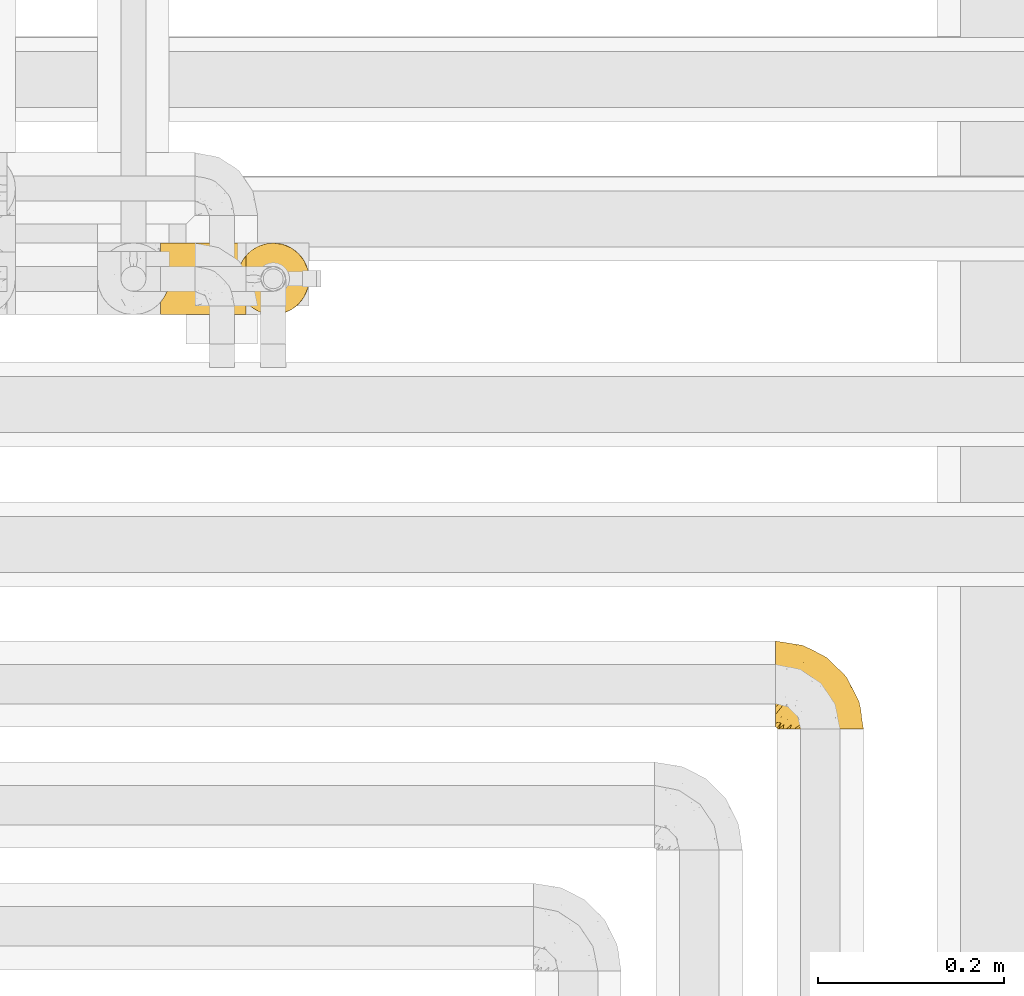
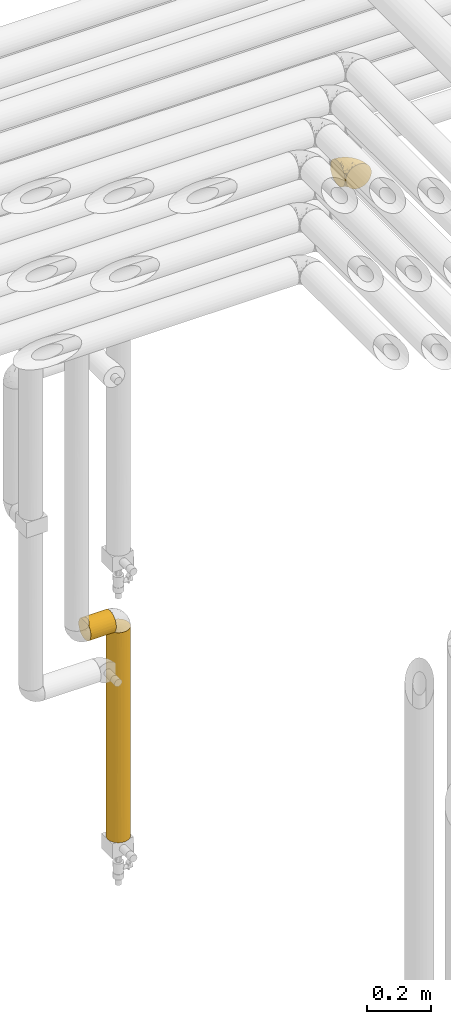
# One storey, part 278 of 827: 3 coverings.
"""IFC2X3 building model written with IfcOpenShell, lengths in millimetres."""

from ifc_helpers import new_model, entity, si_unit, converted_unit, derived_unit, direction, frame, origin, place, context, subcontext, project, spatial, faceted_brep, element, save


model = new_model("IFC2X3")

# Units and contexts
model_context = context("Model", 3, precision=0.01, world=origin(), true_north=direction((6.12303176911189e-17, 1.0)))
body_context = subcontext(model_context, "Body", "Model", "MODEL_VIEW")
ifc_project = project(units=[si_unit("LENGTHUNIT", "METRE", prefix="MILLI"), si_unit("AREAUNIT", "SQUARE_METRE"), si_unit("VOLUMEUNIT", "CUBIC_METRE"), converted_unit("PLANEANGLEUNIT", "DEGREE", entity("IfcRatioMeasure", 0.0174532925199433), si_unit("PLANEANGLEUNIT", "RADIAN"), dimensions=[0, 0, 0, 0, 0, 0, 0]), si_unit("MASSUNIT", "GRAM", prefix="KILO"), derived_unit("MASSDENSITYUNIT", [(si_unit("MASSUNIT", "GRAM", prefix="KILO"), 1), (si_unit("LENGTHUNIT", "METRE"), -3)]), derived_unit("MOMENTOFINERTIAUNIT", [(si_unit("LENGTHUNIT", "METRE"), 4)]), si_unit("TIMEUNIT", "SECOND"), si_unit("FREQUENCYUNIT", "HERTZ"), si_unit("THERMODYNAMICTEMPERATUREUNIT", "DEGREE_CELSIUS"), derived_unit("THERMALTRANSMITTANCEUNIT", [(si_unit("MASSUNIT", "GRAM", prefix="KILO"), 1), (si_unit("THERMODYNAMICTEMPERATUREUNIT", "KELVIN"), -1), (si_unit("TIMEUNIT", "SECOND"), -3)]), derived_unit("VOLUMETRICFLOWRATEUNIT", [(si_unit("LENGTHUNIT", "METRE"), 3), (si_unit("TIMEUNIT", "SECOND"), -1)]), derived_unit("MASSFLOWRATEUNIT", [(si_unit("MASSUNIT", "GRAM", prefix="KILO"), 1), (si_unit("TIMEUNIT", "SECOND"), -1)]), derived_unit("ROTATIONALFREQUENCYUNIT", [(si_unit("TIMEUNIT", "SECOND"), -1)]), si_unit("ELECTRICCURRENTUNIT", "AMPERE"), si_unit("ELECTRICVOLTAGEUNIT", "VOLT"), si_unit("POWERUNIT", "WATT"), si_unit("FORCEUNIT", "NEWTON", prefix="KILO"), si_unit("ILLUMINANCEUNIT", "LUX"), si_unit("LUMINOUSFLUXUNIT", "LUMEN"), si_unit("LUMINOUSINTENSITYUNIT", "CANDELA"), derived_unit("USERDEFINED", [(si_unit("MASSUNIT", "GRAM", prefix="KILO"), -1), (si_unit("LENGTHUNIT", "METRE"), -2), (si_unit("TIMEUNIT", "SECOND"), 3), (si_unit("LUMINOUSFLUXUNIT", "LUMEN"), 1)]), derived_unit("LINEARVELOCITYUNIT", [(si_unit("LENGTHUNIT", "METRE"), 1), (si_unit("TIMEUNIT", "SECOND"), -1)]), si_unit("PRESSUREUNIT", "PASCAL"), derived_unit("USERDEFINED", [(si_unit("LENGTHUNIT", "METRE"), -2), (si_unit("MASSUNIT", "GRAM", prefix="KILO"), 1), (si_unit("TIMEUNIT", "SECOND"), -2)]), derived_unit("LINEARFORCEUNIT", [(si_unit("MASSUNIT", "GRAM", prefix="KILO"), 1), (si_unit("LENGTHUNIT", "METRE"), 1), (si_unit("TIMEUNIT", "SECOND"), -2), (si_unit("LENGTHUNIT", "METRE"), -1)]), derived_unit("PLANARFORCEUNIT", [(si_unit("MASSUNIT", "GRAM", prefix="KILO"), 1), (si_unit("LENGTHUNIT", "METRE"), 1), (si_unit("TIMEUNIT", "SECOND"), -2), (si_unit("LENGTHUNIT", "METRE"), -2)])], contexts=[model_context])

# Site, building, storey
site_placement = place(None, origin())
site = spatial("IfcSite", under=ifc_project, at=site_placement, CompositionType="ELEMENT")
building_placement = place(site_placement, origin())
building = spatial("IfcBuilding", under=site, at=building_placement, CompositionType="ELEMENT")
storey_placement = place(building_placement, frame((0.0, 0.0, 28200.0)))
storey = spatial("IfcBuildingStorey", under=building, at=storey_placement, Name="08", CompositionType="ELEMENT", Elevation=28200.0)

# Coverings
covering_1_placement = place(storey_placement, frame((35680.44, 14440.41, 2952.2)))
element("IfcCovering", 1, at=covering_1_placement, inside=storey, Name=":ADSK_", ObjectType=":ADSK_", PredefinedType="INSULATION", context=body_context, shape_type="Brep", body=[
    faceted_brep([(1.6, 59.88, 92.84), (1.6, 69.65, 89.42), (1.6, 78.41, 83.91), (1.6, 85.72, 76.59), (1.6, 91.22, 67.83), (1.6, 94.64, 58.07), (1.6, 95.8, 47.8), (1.6, 94.64, 37.51), (1.6, 91.22, 27.74), (1.6, 85.71, 18.98), (1.6, 78.39, 11.67), (1.6, 69.63, 6.17), (1.6, 59.87, 2.75), (1.6, 49.6, 1.6), (1.6, 45.45, 2.06), (1.6, 42.38, 2.41), (1.6, 39.31, 2.75), (1.6, 34.43, 4.46), (1.6, 29.54, 6.17), (1.6, 25.16, 8.93), (1.6, 20.78, 11.68), (1.6, 17.13, 15.34), (1.6, 13.47, 19.0), (1.6, 7.97, 27.76), (1.6, 6.26, 32.64), (1.6, 4.55, 37.52), (1.6, 3.4, 47.8), (1.6, 4.55, 58.08), (1.6, 6.26, 62.96), (1.6, 7.97, 67.85), (1.6, 13.48, 76.61), (1.6, 17.14, 80.26), (1.6, 20.8, 83.92), (1.6, 25.18, 86.67), (1.6, 29.56, 89.42), (1.6, 34.44, 91.13), (1.6, 39.32, 92.84), (1.6, 42.39, 93.18), (1.6, 45.45, 93.53), (1.6, 49.6, 94.0), (3.4, 1.6, 47.8), (4.97, 1.6, 35.84), (9.58, 1.6, 24.7), (13.26, 1.6, 19.91), (16.93, 1.6, 15.13), (21.71, 1.6, 11.46), (26.5, 1.6, 7.78), (32.07, 1.6, 5.48), (37.64, 1.6, 3.17), (41.25, 1.6, 2.69), (43.34, 1.6, 2.42), (45.42, 1.6, 2.14), (49.6, 1.6, 1.6), (61.55, 1.6, 3.17), (72.7, 1.6, 7.78), (82.26, 1.6, 15.13), (89.61, 1.6, 24.7), (94.22, 1.6, 35.84), (95.8, 1.6, 47.8), (94.22, 1.6, 59.75), (89.61, 1.6, 70.9), (82.26, 1.6, 80.46), (72.7, 1.6, 87.81), (61.55, 1.6, 92.42), (49.6, 1.6, 94.0), (45.42, 1.6, 93.45), (41.25, 1.6, 92.9), (37.64, 1.6, 92.42), (32.07, 1.6, 90.11), (26.5, 1.6, 87.81), (21.71, 1.6, 84.13), (16.93, 1.6, 80.46), (13.26, 1.6, 75.68), (9.58, 1.6, 70.9), (4.97, 1.6, 59.75), (81.55, 36.81, 71.98), (90.4, 23.28, 63.6), (83.0, 45.8, 59.72), (91.18, 30.7, 47.8), (93.13, 21.2, 55.16), (94.0, 12.96, 47.8), (66.19, 66.19, 63.76), (70.92, 54.51, 72.22), (85.95, 17.98, 74.18), (49.74, 36.69, 92.52), (35.54, 35.54, 94.0), (38.14, 31.64, 94.0), (40.74, 27.75, 94.0), (43.34, 23.86, 94.0), (45.94, 19.96, 94.0), (77.59, 22.8, 82.14), (71.17, 42.67, 80.34), (65.81, 33.21, 87.52), (59.03, 59.45, 79.59), (45.85, 71.5, 78.25), (45.79, 62.66, 85.01), (41.42, 54.5, 90.25), (34.51, 47.57, 93.2), (56.04, 48.81, 87.23), (15.15, 74.98, 85.55), (56.51, 18.7, 93.0), (68.39, 15.75, 89.31), (23.33, 91.17, 61.31), (42.86, 85.28, 56.86), (39.42, 82.58, 68.34), (53.58, 75.78, 65.71), (59.17, 74.98, 56.99), (59.06, 67.27, 72.15), (22.63, 87.38, 70.34), (20.55, 82.04, 78.36), (12.96, 94.0, 47.8), (56.96, 77.8, 47.8), (67.38, 67.38, 47.8), (18.72, 56.2, 93.06), (5.33, 48.85, 94.0), (9.07, 48.11, 94.0), (11.79, 47.57, 94.0), (14.51, 47.03, 94.0), (17.24, 46.48, 94.0), (19.96, 45.94, 94.0), (21.03, 65.78, 89.88), (46.48, 17.24, 94.0), (47.03, 14.51, 94.0), (47.57, 11.79, 94.0), (48.11, 9.07, 94.0), (48.48, 7.2, 94.0), (48.85, 5.33, 94.0), (30.7, 91.18, 47.8), (23.86, 43.34, 94.0), (27.75, 40.74, 94.0), (31.64, 38.14, 94.0), (31.26, 72.73, 83.7), (77.8, 56.96, 47.8), (72.75, 62.23, 55.9), (43.83, 84.49, 47.8), (84.49, 43.83, 47.8), (14.58, 12.05, 81.75), (16.17, 18.95, 86.43), (10.82, 13.02, 79.8), (4.64, 8.34, 69.84), (7.71, 14.63, 79.5), (25.13, 11.09, 88.08), (32.66, 13.66, 91.6), (34.94, 20.08, 92.93), (36.76, 9.61, 92.43), (40.48, 9.48, 93.24), (39.25, 16.1, 93.36), (3.69, 3.42, 57.25), (13.99, 26.63, 89.41), (21.85, 33.72, 92.89), (17.93, 34.77, 92.66), (15.11, 6.75, 79.58), (21.14, 13.31, 86.51), (7.21, 19.94, 83.91), (9.47, 27.05, 88.76), (32.27, 8.67, 90.94), (25.68, 26.11, 91.94), (22.18, 29.3, 91.98), (18.79, 6.32, 82.79), (10.12, 39.92, 93.16), (10.45, 6.04, 73.94), (11.29, 34.4, 91.89), (2.87, 2.87, 47.8), (31.16, 20.92, 92.22), (12.7, 21.11, 86.29), (6.31, 27.43, 88.56), (25.62, 7.54, 87.72), (21.18, 18.45, 88.33), (28.81, 23.88, 92.18), (7.45, 7.77, 71.78), (21.17, 18.43, 7.27), (16.17, 18.93, 9.17), (25.69, 26.08, 3.66), (48.85, 5.33, 1.6), (47.03, 14.51, 1.6), (47.57, 11.79, 1.6), (48.11, 9.07, 1.6), (3.69, 3.42, 38.35), (7.44, 7.76, 23.84), (14.51, 47.03, 1.6), (11.79, 47.57, 1.6), (5.33, 48.85, 1.6), (9.07, 48.11, 1.6), (7.71, 14.62, 16.1), (9.47, 27.03, 6.84), (34.94, 20.08, 2.66), (31.16, 20.92, 3.37), (40.74, 27.75, 1.6), (38.14, 31.64, 1.6), (18.79, 6.33, 12.8), (36.76, 9.61, 3.16), (40.48, 9.48, 2.35), (4.63, 8.33, 25.77), (21.14, 13.3, 9.09), (15.11, 6.74, 16.02), (14.58, 12.04, 13.85), (43.34, 23.86, 1.6), (45.94, 19.96, 1.6), (39.25, 16.1, 2.23), (7.21, 19.93, 11.69), (12.69, 21.1, 9.31), (10.14, 39.92, 2.43), (21.81, 33.68, 2.71), (22.19, 29.28, 3.61), (14.0, 26.62, 6.18), (6.66, 27.87, 6.77), (17.92, 34.75, 2.93), (10.45, 6.04, 21.66), (31.64, 38.14, 1.6), (10.64, 12.79, 16.09), (11.31, 34.41, 3.7), (19.96, 45.94, 1.6), (23.86, 43.34, 1.6), (27.75, 40.74, 1.6), (32.66, 13.66, 3.99), (46.48, 17.24, 1.6), (32.27, 8.67, 4.65), (25.13, 11.09, 7.51), (35.54, 35.54, 1.6), (28.77, 23.83, 3.43), (23.36, 6.03, 9.46), (17.24, 46.48, 1.6), (47.58, 34.52, 2.4), (93.13, 21.2, 40.43), (77.44, 23.82, 13.57), (66.78, 41.32, 11.3), (71.68, 47.62, 18.65), (74.96, 52.66, 27.26), (81.55, 36.81, 23.61), (36.7, 49.75, 3.07), (56.9, 19.07, 2.69), (83.0, 45.8, 35.87), (90.4, 23.28, 31.99), (67.83, 21.35, 6.71), (85.95, 17.98, 21.41), (39.41, 82.57, 27.24), (23.33, 91.17, 34.26), (42.87, 85.27, 38.73), (53.92, 73.89, 26.97), (66.19, 66.19, 31.83), (64.12, 62.43, 23.4), (33.13, 63.53, 6.91), (23.1, 58.45, 3.4), (16.98, 67.16, 5.84), (55.72, 76.72, 35.73), (72.75, 62.22, 39.69), (23.77, 81.54, 17.6), (18.41, 74.8, 10.38), (43.7, 75.83, 20.6), (54.53, 41.45, 5.36), (17.73, 88.2, 24.84), (38.98, 71.6, 13.87), (50.28, 56.23, 9.06), (59.02, 59.44, 15.99)], [[[0, 1, 2, 3, 4, 5, 6, 7, 8, 9, 10, 11, 12, 13, 14, 15, 16, 17, 18, 19, 20, 21, 22, 23, 24, 25, 26, 27, 28, 29, 30, 31, 32, 33, 34, 35, 36, 37, 38, 39]], [[40, 41, 42, 43, 44, 45, 46, 47, 48, 49, 50, 51, 52, 53, 54, 55, 56, 57, 58, 59, 60, 61, 62, 63, 64, 65, 66, 67, 68, 69, 70, 71, 72, 73, 74]], [[75, 76, 77]], [[78, 79, 80]], [[77, 81, 82]], [[76, 75, 83]], [[84, 85, 86, 87, 88, 89]], [[90, 91, 92]], [[76, 60, 59]], [[93, 94, 95]], [[90, 62, 61]], [[83, 61, 60]], [[96, 97, 84]], [[98, 93, 95]], [[2, 1, 99]], [[100, 84, 89]], [[62, 101, 63]], [[4, 102, 5]], [[92, 84, 100]], [[103, 102, 104]], [[103, 105, 106]], [[93, 107, 94]], [[3, 108, 4]], [[92, 101, 90]], [[108, 3, 109]], [[102, 110, 5]], [[93, 82, 107]], [[102, 108, 104]], [[111, 106, 112]], [[109, 2, 99]], [[113, 39, 114, 115, 116, 117, 118, 119]], [[120, 0, 113]], [[100, 89, 121, 122, 123, 124, 125, 126, 64]], [[127, 102, 103]], [[97, 119, 128, 129, 130, 85]], [[99, 120, 131]], [[132, 133, 77]], [[59, 80, 79]], [[3, 2, 109]], [[98, 84, 92]], [[94, 109, 131]], [[120, 1, 0]], [[93, 91, 82]], [[104, 94, 105]], [[97, 113, 119]], [[95, 120, 96]], [[83, 90, 61]], [[91, 93, 98]], [[64, 63, 100]], [[100, 63, 101]], [[77, 76, 79]], [[133, 106, 81]], [[84, 97, 85]], [[113, 96, 120]], [[113, 97, 96]], [[39, 113, 0]], [[110, 102, 127]], [[110, 6, 5]], [[103, 111, 134, 127]], [[90, 75, 91]], [[82, 81, 107]], [[91, 75, 82]], [[77, 82, 75]], [[76, 83, 60]], [[90, 83, 75]], [[105, 107, 81]], [[94, 131, 95]], [[105, 94, 107]], [[109, 94, 104]], [[120, 95, 131]], [[98, 95, 96]], [[84, 98, 96]], [[98, 92, 91]], [[106, 105, 81]], [[103, 104, 105]], [[133, 132, 112]], [[103, 106, 111]], [[77, 78, 135, 132]], [[106, 133, 112]], [[77, 133, 81]], [[120, 99, 1]], [[109, 99, 131]], [[59, 58, 80]], [[59, 79, 76]], [[90, 101, 62]], [[100, 101, 92]], [[4, 108, 102]], [[109, 104, 108]], [[78, 77, 79]], [[136, 137, 138]], [[29, 139, 140]], [[141, 142, 143]], [[144, 145, 121]], [[146, 89, 88]], [[147, 139, 27]], [[148, 149, 150]], [[136, 151, 152]], [[147, 40, 74]], [[26, 147, 27]], [[153, 148, 154]], [[35, 116, 36]], [[73, 72, 151]], [[114, 39, 38, 37, 36, 116, 115]], [[146, 155, 144]], [[156, 85, 130]], [[157, 149, 148]], [[151, 158, 152]], [[117, 35, 159]], [[31, 153, 154]], [[160, 74, 73]], [[161, 128, 119]], [[66, 65, 64, 126, 125, 124, 123, 122, 67]], [[162, 147, 26]], [[29, 140, 30]], [[149, 129, 150]], [[139, 29, 28, 27]], [[68, 144, 69]], [[129, 128, 150]], [[163, 87, 86]], [[130, 129, 149]], [[122, 145, 67]], [[153, 164, 148]], [[161, 119, 159]], [[165, 32, 154]], [[150, 154, 148]], [[128, 161, 150]], [[32, 165, 33]], [[145, 144, 68]], [[89, 146, 144]], [[87, 163, 143]], [[166, 155, 142]], [[88, 87, 143]], [[161, 154, 150]], [[154, 32, 31]], [[31, 30, 153]], [[30, 140, 153]], [[164, 153, 140]], [[140, 137, 164]], [[157, 148, 164]], [[156, 130, 157]], [[164, 137, 157]], [[157, 137, 156]], [[167, 137, 136]], [[168, 85, 156]], [[152, 168, 167]], [[167, 168, 156]], [[163, 152, 141]], [[71, 158, 72]], [[152, 167, 136]], [[88, 142, 146]], [[144, 155, 69]], [[146, 142, 155]], [[70, 166, 71]], [[142, 141, 166]], [[70, 69, 155]], [[141, 158, 71]], [[160, 73, 151]], [[138, 137, 140]], [[160, 136, 169]], [[136, 160, 151]], [[74, 160, 169]], [[152, 158, 141]], [[151, 72, 158]], [[168, 152, 163]], [[137, 167, 156]], [[163, 86, 168]], [[85, 168, 86]], [[116, 35, 117]], [[130, 149, 157]], [[67, 145, 68]], [[121, 89, 144]], [[145, 122, 121]], [[40, 147, 162]], [[169, 147, 74]], [[159, 35, 34]], [[161, 159, 34]], [[159, 119, 118, 117]], [[139, 147, 169]], [[139, 169, 138]], [[161, 34, 33]], [[141, 143, 163]], [[88, 143, 142]], [[71, 166, 141]], [[155, 166, 70]], [[139, 138, 140]], [[169, 136, 138]], [[154, 161, 165]], [[161, 33, 165]], [[170, 171, 172]], [[173, 52, 51, 50, 49, 48, 174, 175, 176]], [[177, 178, 41]], [[179, 17, 180]], [[14, 13, 181, 182, 180, 16, 15]], [[183, 23, 22]], [[21, 20, 184]], [[185, 186, 187]], [[186, 188, 187]], [[43, 189, 44]], [[190, 191, 47]], [[25, 24, 23, 192]], [[193, 194, 195]], [[40, 162, 177]], [[196, 197, 198]], [[26, 25, 177]], [[199, 200, 183]], [[201, 17, 179]], [[47, 46, 190]], [[202, 203, 204]], [[203, 172, 171]], [[205, 206, 184]], [[207, 41, 178]], [[18, 17, 201]], [[16, 180, 17]], [[204, 203, 200]], [[208, 203, 202]], [[162, 26, 177]], [[48, 47, 191]], [[198, 197, 190]], [[199, 184, 204]], [[171, 195, 209]], [[210, 211, 212]], [[206, 212, 213]], [[205, 19, 210]], [[184, 206, 204]], [[210, 212, 206]], [[185, 196, 214]], [[190, 215, 191]], [[216, 45, 214]], [[186, 217, 193]], [[190, 216, 198]], [[199, 22, 21]], [[196, 185, 187]], [[199, 183, 22]], [[184, 199, 21]], [[199, 204, 200]], [[206, 202, 204]], [[171, 183, 200]], [[203, 208, 172]], [[172, 208, 218]], [[171, 200, 203]], [[218, 188, 219]], [[195, 170, 193]], [[217, 186, 185]], [[193, 219, 186]], [[193, 170, 219]], [[207, 194, 42]], [[217, 220, 189]], [[216, 190, 46]], [[214, 196, 198]], [[44, 220, 45]], [[214, 198, 216]], [[216, 46, 45]], [[214, 45, 220]], [[42, 194, 43]], [[189, 193, 217]], [[207, 195, 194]], [[209, 195, 178]], [[41, 207, 42]], [[195, 207, 178]], [[43, 194, 189]], [[193, 189, 194]], [[171, 170, 195]], [[170, 172, 219]], [[218, 219, 172]], [[188, 186, 219]], [[206, 213, 202]], [[208, 202, 213]], [[201, 210, 18]], [[215, 190, 197]], [[215, 174, 191]], [[174, 48, 191]], [[201, 179, 221, 211]], [[210, 201, 211]], [[25, 192, 177]], [[40, 177, 41]], [[178, 177, 192]], [[23, 183, 192]], [[209, 192, 183]], [[205, 20, 19]], [[19, 18, 210]], [[217, 185, 214]], [[189, 220, 44]], [[214, 220, 217]], [[192, 209, 178]], [[171, 209, 183]], [[206, 205, 210]], [[20, 205, 184]], [[222, 197, 196, 187, 188, 218]], [[57, 223, 80]], [[224, 225, 226]], [[226, 227, 228]], [[229, 218, 208, 213, 212, 211]], [[230, 52, 173, 176, 175, 174, 215, 197]], [[231, 232, 228]], [[231, 78, 223]], [[223, 57, 232]], [[224, 233, 225]], [[233, 54, 53]], [[234, 232, 56]], [[56, 55, 234]], [[234, 224, 228]], [[235, 236, 237]], [[224, 55, 54]], [[238, 239, 240]], [[52, 230, 53]], [[241, 242, 243]], [[239, 244, 245]], [[13, 12, 242]], [[236, 8, 7]], [[9, 246, 10]], [[10, 247, 11]], [[238, 248, 235]], [[222, 229, 249]], [[242, 211, 221, 179, 180, 182, 181, 13]], [[233, 53, 230]], [[111, 112, 244]], [[250, 8, 236]], [[247, 251, 241]], [[8, 250, 9]], [[127, 236, 110]], [[249, 229, 252]], [[247, 10, 246]], [[235, 246, 250]], [[236, 7, 110]], [[235, 244, 238]], [[237, 236, 127]], [[243, 11, 247]], [[252, 229, 241]], [[56, 232, 57]], [[222, 230, 197]], [[225, 249, 252]], [[249, 233, 230]], [[54, 233, 224]], [[231, 228, 227]], [[245, 132, 231]], [[249, 225, 233]], [[226, 225, 253]], [[235, 250, 236]], [[246, 9, 250]], [[251, 247, 246]], [[243, 247, 241]], [[248, 246, 235]], [[252, 251, 253]], [[229, 222, 218]], [[230, 222, 249]], [[7, 6, 110]], [[237, 127, 134, 111]], [[238, 244, 239]], [[224, 234, 55]], [[232, 234, 228]], [[242, 241, 229]], [[12, 11, 243]], [[211, 242, 229]], [[12, 243, 242]], [[80, 223, 78]], [[80, 58, 57]], [[231, 223, 232]], [[227, 240, 239]], [[224, 226, 228]], [[240, 226, 253]], [[227, 239, 245]], [[226, 240, 227]], [[251, 248, 253]], [[240, 253, 248]], [[244, 235, 237]], [[237, 111, 244]], [[132, 245, 112]], [[112, 245, 244]], [[135, 78, 231, 132]], [[227, 245, 231]], [[248, 238, 240]], [[246, 248, 251]], [[251, 252, 241]], [[225, 252, 253]]]),
])
covering_2_placement = place(storey_placement, frame((35020.39, 14884.92, 1190.0)))
element("IfcCovering", 2, at=covering_2_placement, inside=storey, Name=":ADSK_", ObjectType=":ADSK_", PredefinedType="INSULATION", context=body_context, shape_type="Brep", body=[
    faceted_brep([(93.4, 77.51, 31.79), (93.4, 78.4, 40.0), (93.4, 77.09, 49.93), (93.4, 73.25, 59.2), (93.4, 67.15, 67.15), (93.4, 59.2, 73.25), (93.4, 49.93, 77.09), (93.4, 40.0, 78.4), (93.4, 30.06, 77.09), (93.4, 20.8, 73.25), (93.4, 12.84, 67.15), (93.4, 6.74, 59.2), (93.4, 2.9, 49.93), (93.4, 1.6, 40.0), (93.4, 2.48, 31.79), (93.4, 5.09, 23.98), (93.4, 9.31, 16.91), (93.4, 14.94, 10.9), (93.4, 65.05, 10.9), (93.4, 70.68, 16.91), (93.4, 74.9, 23.98), (1.6, 77.51, 48.2), (1.6, 78.4, 40.0), (1.6, 77.09, 30.06), (1.6, 73.25, 20.8), (1.6, 67.15, 12.84), (1.6, 59.2, 6.74), (1.6, 49.93, 2.9), (1.6, 40.0, 1.6), (1.6, 30.06, 2.9), (1.6, 20.8, 6.74), (1.6, 12.84, 12.84), (1.6, 6.74, 20.8), (1.6, 2.9, 30.06), (1.6, 1.6, 40.0), (1.6, 2.48, 48.2), (1.6, 5.09, 56.01), (1.6, 9.31, 63.08), (1.6, 14.94, 69.1), (1.6, 65.05, 69.1), (1.6, 70.68, 63.08), (1.6, 74.9, 56.01), (86.5, 26.63, 4.0), (84.7, 33.21, 2.2), (84.1, 40.0, 1.6), (89.42, 20.48, 6.92), (84.7, 46.78, 2.2), (86.5, 53.36, 4.0), (89.42, 59.51, 6.92), (5.57, 59.51, 73.07), (8.5, 53.36, 76.0), (10.29, 46.78, 77.79), (10.9, 40.0, 78.4), (10.29, 33.21, 77.79), (8.5, 26.63, 76.0), (5.57, 20.48, 73.07)], [[[0, 1, 2, 3, 4, 5, 6, 7, 8, 9, 10, 11, 12, 13, 14, 15, 16, 17, 18, 19, 20]], [[21, 22, 23, 24, 25, 26, 27, 28, 29, 30, 31, 32, 33, 34, 35, 36, 37, 38, 39, 40, 41]], [[34, 33, 14]], [[32, 31, 16]], [[33, 32, 15]], [[14, 13, 34]], [[16, 15, 32]], [[14, 33, 15]], [[31, 17, 16]], [[42, 30, 29]], [[29, 28, 43]], [[44, 43, 28]], [[45, 17, 30]], [[43, 42, 29]], [[45, 30, 42]], [[30, 17, 31]], [[46, 44, 28]], [[46, 28, 27]], [[47, 27, 26]], [[47, 46, 27]], [[18, 48, 26]], [[47, 26, 48]], [[26, 25, 18]], [[19, 25, 24]], [[20, 24, 23]], [[0, 23, 22]], [[19, 24, 20]], [[20, 23, 0]], [[22, 1, 0]], [[25, 19, 18]], [[1, 22, 21]], [[2, 21, 41]], [[3, 41, 40]], [[1, 21, 2]], [[2, 41, 3]], [[40, 4, 3]], [[40, 39, 4]], [[39, 49, 5]], [[50, 51, 6]], [[49, 50, 5]], [[5, 50, 6]], [[7, 6, 51]], [[52, 7, 51]], [[39, 5, 4]], [[53, 54, 8]], [[55, 38, 9]], [[54, 55, 9]], [[52, 53, 7]], [[7, 53, 8]], [[54, 9, 8]], [[38, 10, 9]], [[11, 37, 36]], [[12, 36, 35]], [[13, 35, 34]], [[10, 37, 11]], [[11, 36, 12]], [[35, 13, 12]], [[37, 10, 38]], [[46, 47, 48, 18, 17, 45, 42, 43, 44]], [[38, 55, 54, 53, 52, 51, 50, 49, 39]]]),
])
covering_3_placement = place(storey_placement, frame((35102.89, 14884.92, 401.0)))
element("IfcCovering", 3, at=covering_3_placement, inside=storey, Name=":ADSK_", ObjectType=":ADSK_", PredefinedType="INSULATION", context=body_context, shape_type="Brep", body=[
    faceted_brep([(73.25, 20.8, 799.9), (77.09, 30.06, 799.9), (78.4, 40.0, 799.9), (77.09, 49.93, 799.9), (73.25, 59.2, 799.9), (67.15, 67.15, 799.9), (59.2, 73.25, 799.9), (49.93, 77.09, 799.9), (40.0, 78.4, 799.9), (31.79, 77.51, 799.9), (23.98, 74.9, 799.9), (16.91, 70.68, 799.9), (10.9, 65.05, 799.9), (10.9, 14.94, 799.9), (16.91, 9.31, 799.9), (23.98, 5.09, 799.9), (31.79, 2.48, 799.9), (40.0, 1.6, 799.9), (49.93, 2.9, 799.9), (59.2, 6.74, 799.9), (67.15, 12.84, 799.9), (73.25, 20.8, 0.0), (67.15, 12.84, 0.0), (59.2, 6.74, 0.0), (49.93, 2.9, 0.0), (40.0, 1.6, 0.0), (30.06, 2.9, 0.0), (20.8, 6.74, 0.0), (12.84, 12.84, 0.0), (6.74, 20.8, 0.0), (2.9, 30.06, 0.0), (1.6, 40.0, 0.0), (2.9, 49.93, 0.0), (6.74, 59.2, 0.0), (12.84, 67.15, 0.0), (20.8, 73.25, 0.0), (30.06, 77.09, 0.0), (40.0, 78.4, 0.0), (49.93, 77.09, 0.0), (59.2, 73.25, 0.0), (67.15, 67.15, 0.0), (73.25, 59.2, 0.0), (77.09, 49.93, 0.0), (78.4, 40.0, 0.0), (77.09, 30.06, 0.0), (40.0, 1.6, 367.15), (27.97, 3.53, 271.49), (4.35, 25.71, 239.87), (5.6, 22.92, 499.14), (2.98, 29.79, 484.01), (2.14, 33.54, 212.97), (8.95, 17.39, 396.48), (13.75, 11.96, 561.51), (4.0, 26.63, 793.0), (2.2, 33.21, 791.2), (18.9, 7.91, 202.17), (20.33, 7.01, 408.64), (14.17, 11.58, 325.66), (27.82, 3.58, 550.08), (40.0, 1.6, 583.53), (10.17, 15.81, 185.77), (1.6, 40.0, 574.23), (8.86, 17.51, 609.24), (6.92, 20.48, 795.93), (20.33, 7.01, 622.33), (1.6, 40.0, 357.85), (1.6, 40.0, 790.6), (54.69, 4.52, 240.49), (70.46, 16.62, 240.49), (75.81, 26.15, 183.34), (47.11, 2.26, 475.34), (46.85, 2.21, 239.41), (63.37, 9.53, 626.16), (54.69, 4.52, 521.23), (63.37, 9.53, 399.95), (63.37, 9.53, 173.74), (75.47, 25.3, 399.95), (70.46, 16.62, 521.23), (77.79, 33.21, 237.5), (75.96, 26.54, 612.27), (78.4, 40.0, 199.97), (78.4, 40.0, 367.15), (78.4, 40.0, 399.95), (78.4, 40.0, 583.53), (77.66, 32.5, 491.74), (75.47, 54.69, 240.49), (63.37, 70.46, 240.49), (53.84, 75.81, 183.34), (77.73, 47.11, 475.34), (77.78, 46.85, 239.41), (70.46, 63.37, 626.16), (75.47, 54.69, 521.23), (70.46, 63.37, 173.74), (70.46, 63.37, 399.95), (54.69, 75.47, 399.95), (63.37, 70.46, 521.23), (46.78, 77.79, 237.5), (53.45, 75.96, 612.27), (40.0, 78.4, 199.97), (40.0, 78.4, 367.15), (40.0, 78.4, 399.95), (40.0, 78.4, 583.53), (47.49, 77.66, 491.74), (18.9, 72.08, 202.17), (27.97, 76.47, 271.49), (27.82, 76.41, 550.08), (13.75, 68.03, 561.51), (8.86, 62.48, 609.24), (5.6, 57.07, 499.14), (8.95, 62.6, 396.48), (14.17, 68.41, 325.66), (20.33, 72.98, 408.64), (20.33, 72.98, 622.33), (2.2, 46.78, 791.2), (2.98, 50.2, 484.01), (4.0, 53.36, 793.0), (2.14, 46.45, 212.97), (6.92, 59.51, 795.93), (4.35, 54.28, 239.87), (10.17, 64.19, 185.77)], [[[0, 1, 2, 3, 4, 5, 6, 7, 8, 9, 10, 11, 12, 13, 14, 15, 16, 17, 18, 19, 20]], [[21, 22, 23, 24, 25, 26, 27, 28, 29, 30, 31, 32, 33, 34, 35, 36, 37, 38, 39, 40, 41, 42, 43, 44]], [[45, 46, 25]], [[47, 48, 49]], [[50, 31, 30]], [[47, 51, 48]], [[52, 14, 13]], [[53, 54, 49]], [[55, 56, 57]], [[58, 45, 59]], [[46, 27, 26]], [[53, 49, 48]], [[28, 57, 60]], [[54, 61, 49]], [[62, 13, 63]], [[48, 51, 62]], [[52, 57, 56]], [[59, 17, 16]], [[47, 50, 30]], [[52, 62, 51]], [[46, 56, 55]], [[58, 59, 16]], [[46, 45, 58]], [[14, 64, 15]], [[64, 52, 56]], [[15, 64, 58]], [[16, 15, 58]], [[57, 52, 51]], [[63, 53, 48]], [[62, 52, 13]], [[46, 26, 25]], [[46, 58, 56]], [[48, 62, 63]], [[50, 49, 65]], [[30, 29, 47]], [[47, 29, 60]], [[52, 64, 14]], [[58, 64, 56]], [[60, 57, 51]], [[55, 28, 27]], [[47, 60, 51]], [[29, 28, 60]], [[28, 55, 57]], [[46, 55, 27]], [[49, 50, 47]], [[31, 50, 65]], [[61, 54, 66]], [[61, 65, 49]], [[24, 23, 67]], [[68, 21, 69]], [[70, 45, 71]], [[72, 73, 67, 74]], [[71, 25, 24]], [[22, 75, 23]], [[45, 70, 59]], [[72, 20, 19]], [[19, 18, 73]], [[76, 77, 68]], [[74, 75, 68, 77, 72]], [[69, 44, 78]], [[79, 77, 76]], [[78, 43, 80, 81, 82]], [[72, 77, 20]], [[21, 68, 22]], [[18, 59, 70]], [[0, 20, 77]], [[2, 1, 83]], [[76, 84, 79]], [[70, 71, 67]], [[82, 84, 78]], [[67, 23, 75]], [[1, 79, 84]], [[18, 17, 59]], [[67, 73, 70]], [[18, 70, 73]], [[25, 71, 45]], [[24, 67, 71]], [[1, 84, 83]], [[82, 83, 84]], [[76, 69, 78]], [[76, 78, 84]], [[43, 78, 44]], [[1, 0, 79]], [[77, 79, 0]], [[68, 69, 76]], [[21, 44, 69]], [[73, 72, 19]], [[68, 75, 22]], [[67, 75, 74]], [[42, 41, 85]], [[86, 39, 87]], [[88, 81, 89]], [[90, 91, 85, 92, 93]], [[89, 43, 42]], [[40, 92, 41]], [[88, 83, 82, 81]], [[90, 5, 4]], [[4, 3, 91]], [[94, 95, 86]], [[93, 92, 86, 95, 90]], [[87, 38, 96]], [[97, 95, 94]], [[96, 37, 98, 99, 100]], [[90, 95, 5]], [[39, 86, 40]], [[3, 83, 88]], [[6, 5, 95]], [[8, 7, 101]], [[94, 102, 97]], [[88, 89, 85]], [[100, 102, 96]], [[85, 41, 92]], [[7, 97, 102]], [[3, 2, 83]], [[85, 91, 88]], [[3, 88, 91]], [[89, 81, 80, 43]], [[42, 85, 89]], [[7, 102, 101]], [[100, 101, 102]], [[94, 87, 96]], [[94, 96, 102]], [[37, 96, 38]], [[7, 6, 97]], [[95, 97, 6]], [[86, 87, 94]], [[39, 38, 87]], [[91, 90, 4]], [[86, 92, 40]], [[103, 104, 35]], [[9, 101, 105]], [[9, 105, 10]], [[106, 107, 12]], [[108, 107, 109]], [[109, 106, 110]], [[111, 105, 104]], [[104, 37, 36]], [[34, 110, 103]], [[111, 112, 105]], [[112, 11, 10]], [[104, 105, 99]], [[107, 106, 109]], [[35, 104, 36]], [[106, 12, 11]], [[112, 106, 11]], [[61, 113, 114]], [[104, 99, 98, 37]], [[113, 115, 114]], [[65, 116, 31]], [[12, 107, 117]], [[113, 61, 66]], [[108, 115, 117]], [[118, 116, 114]], [[119, 109, 110]], [[116, 118, 32]], [[108, 118, 114]], [[110, 106, 111]], [[108, 117, 107]], [[109, 119, 118]], [[115, 108, 114]], [[109, 118, 108]], [[33, 32, 118]], [[105, 112, 10]], [[106, 112, 111]], [[103, 110, 111]], [[119, 110, 34]], [[34, 33, 119]], [[118, 119, 33]], [[104, 103, 111]], [[34, 103, 35]], [[31, 116, 32]], [[114, 116, 65]], [[114, 65, 61]], [[101, 9, 8]], [[105, 101, 100, 99]], [[113, 66, 54, 53, 63, 13, 12, 117, 115]]]),
])

save(model, "model.ifc")
